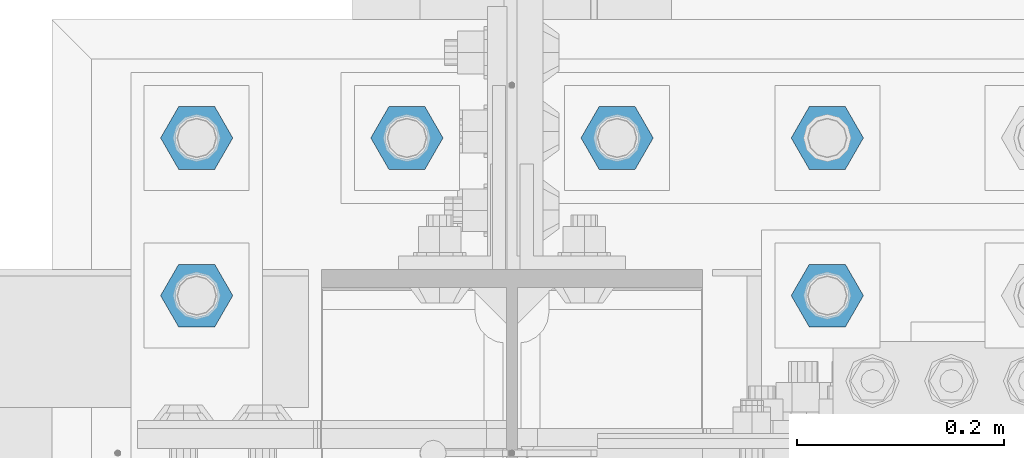
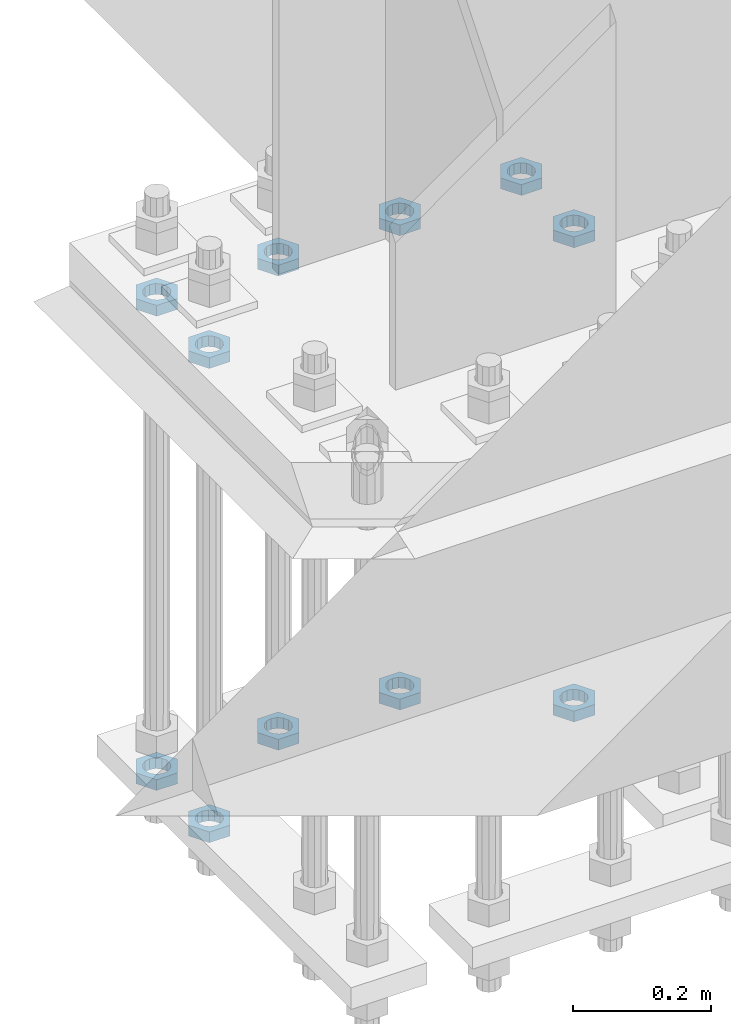
# One storey, part 2793 of 3843: 11 beams, 1 element without a shape of its own.
"""IFC2X3 building model written with IfcOpenShell, lengths in millimetres."""

from ifc_helpers import new_model, si_unit, frame, origin_with_axes, place, context, subcontext, project, spatial, faceted_brep, material, type_object, element, aggregate, save


model = new_model("IFC2X3")

# Units and contexts
model_context = context("Model", 3, precision=1e-05, world=origin_with_axes())
body_context = subcontext(model_context, "Body", "Model", "MODEL_VIEW")
ifc_project = project(units=[si_unit("LENGTHUNIT", "METRE", prefix="MILLI"), si_unit("AREAUNIT", "SQUARE_METRE"), si_unit("VOLUMEUNIT", "CUBIC_METRE"), si_unit("MASSUNIT", "GRAM", prefix="KILO"), si_unit("TIMEUNIT", "SECOND"), si_unit("PLANEANGLEUNIT", "RADIAN"), si_unit("SOLIDANGLEUNIT", "STERADIAN"), si_unit("THERMODYNAMICTEMPERATUREUNIT", "DEGREE_CELSIUS"), si_unit("LUMINOUSINTENSITYUNIT", "LUMEN")], contexts=[model_context])

# Site, building, storey
site_placement = place(None, origin_with_axes())
site = spatial("IfcSite", under=ifc_project, at=site_placement, CompositionType="ELEMENT")
building_placement = place(site_placement, origin_with_axes())
building = spatial("IfcBuilding", under=site, at=building_placement, Name="Undefined", CompositionType="ELEMENT")
storey_placement = place(building_placement, origin_with_axes())
storey = spatial("IfcBuildingStorey", under=building, at=storey_placement, Name="Undefined", CompositionType="ELEMENT", Elevation=0.0)

# Assembly, beams
assembly_placement = place(storey_placement, origin_with_axes())
assembly = element("IfcElementAssembly", 1, at=assembly_placement, inside=storey, Name="TEMPLATE", AssemblyPlace="NOTDEFINED", PredefinedType="RIGID_FRAME")
ifc_material = material(Name="STEEL/A572-50")
beam_type = type_object("IfcBeamType", Name="1-1/2_HALF_NUT", PredefinedType="NOTDEFINED")
beam_1_placement = place(assembly_placement, frame((42367.2, 25920.7, 29603.7), z_axis=(0.0, 1.0, 0.0), x_axis=(0.0, 0.0, -1.0)))
beam_1 = element("IfcBeam", 2, at=beam_1_placement, type_object=beam_type, material=ifc_material, Name="NUT", ObjectType="1-1/2_HALF_NUT", context=body_context, shape_type="Brep", body=[
    faceted_brep([(0.0, -34.9199981689453, 0.0), (0.0, -17.4599990844727, -30.25), (19.0500000000029, -17.4599990844727, -30.25), (19.0500000000029, -34.9199981689453, 0.0), (0.0, 17.4599990844727, -30.25), (19.0500000000029, 17.4599990844727, -30.25), (0.0, 34.9199981689453, 0.0), (19.0500000000029, 34.9199981689453, 0.0), (0.0, 17.4599990844727, 30.25), (19.0500000000029, 17.4599990844727, 30.25), (0.0, -17.4599990844727, 30.25), (19.0500000000029, -17.4599990844727, 30.25), (0.0, 0.0, 20.6399993896484), (0.0, 8.9553601105581, 18.5959968835959), (19.0500000000029, 8.95536011056538, 18.5959968835959), (19.0500000000029, 0.0, 20.6399993896484), (0.0, 16.1370013209525, 12.8688291298167), (19.0500000000029, 16.1370013209489, 12.8688291298167), (0.0, 20.1225115123816, 4.59283194104501), (19.0500000000029, 20.1225115123852, 4.59283194104501), (0.0, 20.1225115123816, -4.59283194104501), (19.0500000000029, 20.1225115123852, -4.59283194104501), (0.0, 16.1370013209525, -12.8688291298167), (19.0500000000029, 16.1370013209489, -12.8688291298167), (0.0, 8.9553601105581, -18.5959968835959), (19.0500000000029, 8.95536011056538, -18.5959968835959), (0.0, 0.0, -20.6399993896484), (19.0500000000029, 0.0, -20.6399993896484), (0.0, -8.9553601105581, -18.5959968835959), (19.0500000000029, -8.95536011056538, -18.5959968835959), (0.0, -16.1370013209525, -12.8688291298167), (19.0500000000029, -16.1370013209489, -12.8688291298167), (0.0, -20.1225115123816, -4.59283194104501), (19.0500000000029, -20.1225115123852, -4.59283194104501), (0.0, -20.1225115123816, 4.59283194104501), (19.0500000000029, -20.1225115123852, 4.59283194104501), (0.0, -16.1370013209525, 12.8688291298167), (19.0500000000029, -16.1370013209489, 12.8688291298167), (0.0, -8.9553601105581, 18.5959968835959), (19.0500000000029, -8.95536011056538, 18.5959968835959)], [[[0, 1, 2, 3]], [[1, 4, 5, 2]], [[4, 6, 7, 5]], [[6, 8, 9, 7]], [[8, 10, 11, 9]], [[10, 0, 3, 11]], [[12, 13, 14, 15]], [[13, 16, 17, 14]], [[16, 18, 19, 17]], [[18, 20, 21, 19]], [[20, 22, 23, 21]], [[22, 24, 25, 23]], [[24, 26, 27, 25]], [[26, 28, 29, 27]], [[28, 30, 31, 29]], [[30, 32, 33, 31]], [[32, 34, 35, 33]], [[34, 36, 37, 35]], [[36, 38, 39, 37]], [[38, 12, 15, 39]], [[5, 7, 9, 11, 3, 2], [17, 19, 21, 23, 25, 27, 29, 31, 33, 35, 37, 39, 15, 14]], [[10, 8, 6, 4, 1, 0], [38, 36, 34, 32, 30, 28, 26, 24, 22, 20, 18, 16, 13, 12]]]),
])
beam_2_placement = place(assembly_placement, frame((42367.2, 25768.3, 29603.7), z_axis=(0.0, 1.0, 0.0), x_axis=(0.0, 0.0, -1.0)))
beam_2 = element("IfcBeam", 3, at=beam_2_placement, type_object=beam_type, material=ifc_material, Name="NUT", ObjectType="1-1/2_HALF_NUT", context=body_context, shape_type="Brep", body=[
    faceted_brep([(0.0, -34.9199981689453, 0.0), (0.0, -17.4599990844727, -30.25), (19.0500000000029, -17.4599990844727, -30.25), (19.0500000000029, -34.9199981689453, 0.0), (0.0, 17.4599990844727, -30.25), (19.0500000000029, 17.4599990844727, -30.25), (0.0, 34.9199981689453, 0.0), (19.0500000000029, 34.9199981689453, 0.0), (0.0, 17.4599990844727, 30.25), (19.0500000000029, 17.4599990844727, 30.25), (0.0, -17.4599990844727, 30.25), (19.0500000000029, -17.4599990844727, 30.25), (0.0, 0.0, 20.6399993896484), (0.0, 8.9553601105581, 18.5959968835959), (19.0500000000029, 8.95536011056538, 18.5959968835959), (19.0500000000029, 0.0, 20.6399993896484), (0.0, 16.1370013209525, 12.8688291298167), (19.0500000000029, 16.1370013209489, 12.8688291298167), (0.0, 20.1225115123816, 4.59283194104501), (19.0500000000029, 20.1225115123852, 4.59283194104501), (0.0, 20.1225115123816, -4.59283194104501), (19.0500000000029, 20.1225115123852, -4.59283194104501), (0.0, 16.1370013209525, -12.8688291298167), (19.0500000000029, 16.1370013209489, -12.8688291298167), (0.0, 8.9553601105581, -18.5959968835959), (19.0500000000029, 8.95536011056538, -18.5959968835959), (0.0, 0.0, -20.6399993896484), (19.0500000000029, 0.0, -20.6399993896484), (0.0, -8.9553601105581, -18.5959968835959), (19.0500000000029, -8.95536011056538, -18.5959968835959), (0.0, -16.1370013209525, -12.8688291298167), (19.0500000000029, -16.1370013209489, -12.8688291298167), (0.0, -20.1225115123816, -4.59283194104501), (19.0500000000029, -20.1225115123852, -4.59283194104501), (0.0, -20.1225115123816, 4.59283194104501), (19.0500000000029, -20.1225115123852, 4.59283194104501), (0.0, -16.1370013209525, 12.8688291298167), (19.0500000000029, -16.1370013209489, 12.8688291298167), (0.0, -8.9553601105581, 18.5959968835959), (19.0500000000029, -8.95536011056538, 18.5959968835959)], [[[0, 1, 2, 3]], [[1, 4, 5, 2]], [[4, 6, 7, 5]], [[6, 8, 9, 7]], [[8, 10, 11, 9]], [[10, 0, 3, 11]], [[12, 13, 14, 15]], [[13, 16, 17, 14]], [[16, 18, 19, 17]], [[18, 20, 21, 19]], [[20, 22, 23, 21]], [[22, 24, 25, 23]], [[24, 26, 27, 25]], [[26, 28, 29, 27]], [[28, 30, 31, 29]], [[30, 32, 33, 31]], [[32, 34, 35, 33]], [[34, 36, 37, 35]], [[36, 38, 39, 37]], [[38, 12, 15, 39]], [[5, 7, 9, 11, 3, 2], [17, 19, 21, 23, 25, 27, 29, 31, 33, 35, 37, 39, 15, 14]], [[10, 8, 6, 4, 1, 0], [38, 36, 34, 32, 30, 28, 26, 24, 22, 20, 18, 16, 13, 12]]]),
])
beam_3_placement = place(assembly_placement, frame((42164.0, 25920.7, 29603.7), z_axis=(0.0, -1.0, 0.0), x_axis=(0.0, 0.0, -1.0)))
beam_3 = element("IfcBeam", 4, at=beam_3_placement, type_object=beam_type, material=ifc_material, Name="NUT", ObjectType="1-1/2_HALF_NUT", context=body_context, shape_type="Brep", body=[
    faceted_brep([(0.0, -34.9199981689453, 0.0), (0.0, -17.4599990844727, -30.25), (19.0500000000029, -17.4599990844727, -30.25), (19.0500000000029, -34.9199981689453, 0.0), (0.0, 17.4599990844727, -30.25), (19.0500000000029, 17.4599990844727, -30.25), (0.0, 34.9199981689453, 0.0), (19.0500000000029, 34.9199981689453, 0.0), (0.0, 17.4599990844727, 30.25), (19.0500000000029, 17.4599990844727, 30.25), (0.0, -17.4599990844727, 30.25), (19.0500000000029, -17.4599990844727, 30.25), (0.0, 0.0, 20.6399993896484), (0.0, 8.9553601105581, 18.5959968835959), (19.0500000000029, 8.95536011056538, 18.5959968835959), (19.0500000000029, 0.0, 20.6399993896484), (0.0, 16.1370013209525, 12.8688291298167), (19.0500000000029, 16.1370013209489, 12.8688291298167), (0.0, 20.1225115123816, 4.59283194104501), (19.0500000000029, 20.1225115123852, 4.59283194104501), (0.0, 20.1225115123816, -4.59283194104501), (19.0500000000029, 20.1225115123852, -4.59283194104501), (0.0, 16.1370013209525, -12.8688291298167), (19.0500000000029, 16.1370013209489, -12.8688291298167), (0.0, 8.9553601105581, -18.5959968835959), (19.0500000000029, 8.95536011056538, -18.5959968835959), (0.0, 0.0, -20.6399993896484), (19.0500000000029, 0.0, -20.6399993896484), (0.0, -8.9553601105581, -18.5959968835959), (19.0500000000029, -8.95536011056538, -18.5959968835959), (0.0, -16.1370013209525, -12.8688291298167), (19.0500000000029, -16.1370013209489, -12.8688291298167), (0.0, -20.1225115123816, -4.59283194104501), (19.0500000000029, -20.1225115123852, -4.59283194104501), (0.0, -20.1225115123816, 4.59283194104501), (19.0500000000029, -20.1225115123852, 4.59283194104501), (0.0, -16.1370013209525, 12.8688291298167), (19.0500000000029, -16.1370013209489, 12.8688291298167), (0.0, -8.9553601105581, 18.5959968835959), (19.0500000000029, -8.95536011056538, 18.5959968835959)], [[[0, 1, 2, 3]], [[1, 4, 5, 2]], [[4, 6, 7, 5]], [[6, 8, 9, 7]], [[8, 10, 11, 9]], [[10, 0, 3, 11]], [[12, 13, 14, 15]], [[13, 16, 17, 14]], [[16, 18, 19, 17]], [[18, 20, 21, 19]], [[20, 22, 23, 21]], [[22, 24, 25, 23]], [[24, 26, 27, 25]], [[26, 28, 29, 27]], [[28, 30, 31, 29]], [[30, 32, 33, 31]], [[32, 34, 35, 33]], [[34, 36, 37, 35]], [[36, 38, 39, 37]], [[38, 12, 15, 39]], [[5, 7, 9, 11, 3, 2], [17, 19, 21, 23, 25, 27, 29, 31, 33, 35, 37, 39, 15, 14]], [[10, 8, 6, 4, 1, 0], [38, 36, 34, 32, 30, 28, 26, 24, 22, 20, 18, 16, 13, 12]]]),
])
beam_4_placement = place(assembly_placement, frame((41960.8, 25920.7, 29603.7), z_axis=(0.0, -1.0, 0.0), x_axis=(0.0, 0.0, -1.0)))
beam_4 = element("IfcBeam", 5, at=beam_4_placement, type_object=beam_type, material=ifc_material, Name="NUT", ObjectType="1-1/2_HALF_NUT", context=body_context, shape_type="Brep", body=[
    faceted_brep([(0.0, -34.9199981689453, 0.0), (0.0, -17.4599990844727, -30.25), (19.0500000000029, -17.4599990844727, -30.25), (19.0500000000029, -34.9199981689453, 0.0), (0.0, 17.4599990844727, -30.25), (19.0500000000029, 17.4599990844727, -30.25), (0.0, 34.9199981689453, 0.0), (19.0500000000029, 34.9199981689453, 0.0), (0.0, 17.4599990844727, 30.25), (19.0500000000029, 17.4599990844727, 30.25), (0.0, -17.4599990844727, 30.25), (19.0500000000029, -17.4599990844727, 30.25), (0.0, 0.0, 20.6399993896484), (0.0, 8.9553601105581, 18.5959968835959), (19.0500000000029, 8.95536011056538, 18.5959968835959), (19.0500000000029, 0.0, 20.6399993896484), (0.0, 16.1370013209525, 12.8688291298167), (19.0500000000029, 16.1370013209489, 12.8688291298167), (0.0, 20.1225115123816, 4.59283194104501), (19.0500000000029, 20.1225115123852, 4.59283194104501), (0.0, 20.1225115123816, -4.59283194104501), (19.0500000000029, 20.1225115123852, -4.59283194104501), (0.0, 16.1370013209525, -12.8688291298167), (19.0500000000029, 16.1370013209489, -12.8688291298167), (0.0, 8.9553601105581, -18.5959968835959), (19.0500000000029, 8.95536011056538, -18.5959968835959), (0.0, 0.0, -20.6399993896484), (19.0500000000029, 0.0, -20.6399993896484), (0.0, -8.9553601105581, -18.5959968835959), (19.0500000000029, -8.95536011056538, -18.5959968835959), (0.0, -16.1370013209525, -12.8688291298167), (19.0500000000029, -16.1370013209489, -12.8688291298167), (0.0, -20.1225115123816, -4.59283194104501), (19.0500000000029, -20.1225115123852, -4.59283194104501), (0.0, -20.1225115123816, 4.59283194104501), (19.0500000000029, -20.1225115123852, 4.59283194104501), (0.0, -16.1370013209525, 12.8688291298167), (19.0500000000029, -16.1370013209489, 12.8688291298167), (0.0, -8.9553601105581, 18.5959968835959), (19.0500000000029, -8.95536011056538, 18.5959968835959)], [[[0, 1, 2, 3]], [[1, 4, 5, 2]], [[4, 6, 7, 5]], [[6, 8, 9, 7]], [[8, 10, 11, 9]], [[10, 0, 3, 11]], [[12, 13, 14, 15]], [[13, 16, 17, 14]], [[16, 18, 19, 17]], [[18, 20, 21, 19]], [[20, 22, 23, 21]], [[22, 24, 25, 23]], [[24, 26, 27, 25]], [[26, 28, 29, 27]], [[28, 30, 31, 29]], [[30, 32, 33, 31]], [[32, 34, 35, 33]], [[34, 36, 37, 35]], [[36, 38, 39, 37]], [[38, 12, 15, 39]], [[5, 7, 9, 11, 3, 2], [17, 19, 21, 23, 25, 27, 29, 31, 33, 35, 37, 39, 15, 14]], [[10, 8, 6, 4, 1, 0], [38, 36, 34, 32, 30, 28, 26, 24, 22, 20, 18, 16, 13, 12]]]),
])
beam_5_placement = place(assembly_placement, frame((41757.6, 25920.7, 29603.7), z_axis=(0.0, -1.0, 0.0), x_axis=(0.0, 0.0, -1.0)))
beam_5 = element("IfcBeam", 6, at=beam_5_placement, type_object=beam_type, material=ifc_material, Name="NUT", ObjectType="1-1/2_HALF_NUT", context=body_context, shape_type="Brep", body=[
    faceted_brep([(0.0, -34.9199981689453, 0.0), (0.0, -17.4599990844727, -30.25), (19.0500000000029, -17.4599990844727, -30.25), (19.0500000000029, -34.9199981689453, 0.0), (0.0, 17.4599990844727, -30.25), (19.0500000000029, 17.4599990844727, -30.25), (0.0, 34.9199981689453, 0.0), (19.0500000000029, 34.9199981689453, 0.0), (0.0, 17.4599990844727, 30.25), (19.0500000000029, 17.4599990844727, 30.25), (0.0, -17.4599990844727, 30.25), (19.0500000000029, -17.4599990844727, 30.25), (0.0, 0.0, 20.6399993896484), (0.0, 8.9553601105581, 18.5959968835959), (19.0500000000029, 8.95536011056538, 18.5959968835959), (19.0500000000029, 0.0, 20.6399993896484), (0.0, 16.1370013209525, 12.8688291298167), (19.0500000000029, 16.1370013209489, 12.8688291298167), (0.0, 20.1225115123816, 4.59283194104501), (19.0500000000029, 20.1225115123852, 4.59283194104501), (0.0, 20.1225115123816, -4.59283194104501), (19.0500000000029, 20.1225115123852, -4.59283194104501), (0.0, 16.1370013209525, -12.8688291298167), (19.0500000000029, 16.1370013209489, -12.8688291298167), (0.0, 8.9553601105581, -18.5959968835959), (19.0500000000029, 8.95536011056538, -18.5959968835959), (0.0, 0.0, -20.6399993896484), (19.0500000000029, 0.0, -20.6399993896484), (0.0, -8.9553601105581, -18.5959968835959), (19.0500000000029, -8.95536011056538, -18.5959968835959), (0.0, -16.1370013209525, -12.8688291298167), (19.0500000000029, -16.1370013209489, -12.8688291298167), (0.0, -20.1225115123816, -4.59283194104501), (19.0500000000029, -20.1225115123852, -4.59283194104501), (0.0, -20.1225115123816, 4.59283194104501), (19.0500000000029, -20.1225115123852, 4.59283194104501), (0.0, -16.1370013209525, 12.8688291298167), (19.0500000000029, -16.1370013209489, 12.8688291298167), (0.0, -8.9553601105581, 18.5959968835959), (19.0500000000029, -8.95536011056538, 18.5959968835959)], [[[0, 1, 2, 3]], [[1, 4, 5, 2]], [[4, 6, 7, 5]], [[6, 8, 9, 7]], [[8, 10, 11, 9]], [[10, 0, 3, 11]], [[12, 13, 14, 15]], [[13, 16, 17, 14]], [[16, 18, 19, 17]], [[18, 20, 21, 19]], [[20, 22, 23, 21]], [[22, 24, 25, 23]], [[24, 26, 27, 25]], [[26, 28, 29, 27]], [[28, 30, 31, 29]], [[30, 32, 33, 31]], [[32, 34, 35, 33]], [[34, 36, 37, 35]], [[36, 38, 39, 37]], [[38, 12, 15, 39]], [[5, 7, 9, 11, 3, 2], [17, 19, 21, 23, 25, 27, 29, 31, 33, 35, 37, 39, 15, 14]], [[10, 8, 6, 4, 1, 0], [38, 36, 34, 32, 30, 28, 26, 24, 22, 20, 18, 16, 13, 12]]]),
])
beam_6_placement = place(assembly_placement, frame((41757.6, 25768.3, 29603.7), z_axis=(0.0, -1.0, 0.0), x_axis=(0.0, 0.0, -1.0)))
beam_6 = element("IfcBeam", 7, at=beam_6_placement, type_object=beam_type, material=ifc_material, Name="NUT", ObjectType="1-1/2_HALF_NUT", context=body_context, shape_type="Brep", body=[
    faceted_brep([(0.0, -34.9199981689453, 0.0), (0.0, -17.4599990844727, -30.25), (19.0500000000029, -17.4599990844727, -30.25), (19.0500000000029, -34.9199981689453, 0.0), (0.0, 17.4599990844727, -30.25), (19.0500000000029, 17.4599990844727, -30.25), (0.0, 34.9199981689453, 0.0), (19.0500000000029, 34.9199981689453, 0.0), (0.0, 17.4599990844727, 30.25), (19.0500000000029, 17.4599990844727, 30.25), (0.0, -17.4599990844727, 30.25), (19.0500000000029, -17.4599990844727, 30.25), (0.0, 0.0, 20.6399993896484), (0.0, 8.9553601105581, 18.5959968835959), (19.0500000000029, 8.95536011056538, 18.5959968835959), (19.0500000000029, 0.0, 20.6399993896484), (0.0, 16.1370013209525, 12.8688291298167), (19.0500000000029, 16.1370013209489, 12.8688291298167), (0.0, 20.1225115123816, 4.59283194104501), (19.0500000000029, 20.1225115123852, 4.59283194104501), (0.0, 20.1225115123816, -4.59283194104501), (19.0500000000029, 20.1225115123852, -4.59283194104501), (0.0, 16.1370013209525, -12.8688291298167), (19.0500000000029, 16.1370013209489, -12.8688291298167), (0.0, 8.9553601105581, -18.5959968835959), (19.0500000000029, 8.95536011056538, -18.5959968835959), (0.0, 0.0, -20.6399993896484), (19.0500000000029, 0.0, -20.6399993896484), (0.0, -8.9553601105581, -18.5959968835959), (19.0500000000029, -8.95536011056538, -18.5959968835959), (0.0, -16.1370013209525, -12.8688291298167), (19.0500000000029, -16.1370013209489, -12.8688291298167), (0.0, -20.1225115123816, -4.59283194104501), (19.0500000000029, -20.1225115123852, -4.59283194104501), (0.0, -20.1225115123816, 4.59283194104501), (19.0500000000029, -20.1225115123852, 4.59283194104501), (0.0, -16.1370013209525, 12.8688291298167), (19.0500000000029, -16.1370013209489, 12.8688291298167), (0.0, -8.9553601105581, 18.5959968835959), (19.0500000000029, -8.95536011056538, 18.5959968835959)], [[[0, 1, 2, 3]], [[1, 4, 5, 2]], [[4, 6, 7, 5]], [[6, 8, 9, 7]], [[8, 10, 11, 9]], [[10, 0, 3, 11]], [[12, 13, 14, 15]], [[13, 16, 17, 14]], [[16, 18, 19, 17]], [[18, 20, 21, 19]], [[20, 22, 23, 21]], [[22, 24, 25, 23]], [[24, 26, 27, 25]], [[26, 28, 29, 27]], [[28, 30, 31, 29]], [[30, 32, 33, 31]], [[32, 34, 35, 33]], [[34, 36, 37, 35]], [[36, 38, 39, 37]], [[38, 12, 15, 39]], [[5, 7, 9, 11, 3, 2], [17, 19, 21, 23, 25, 27, 29, 31, 33, 35, 37, 39, 15, 14]], [[10, 8, 6, 4, 1, 0], [38, 36, 34, 32, 30, 28, 26, 24, 22, 20, 18, 16, 13, 12]]]),
])
beam_7_placement = place(assembly_placement, frame((41757.6, 25768.3, 28765.5000015259), z_axis=(0.0, -1.0, 0.0), x_axis=(0.0, 0.0, -1.0)))
beam_7 = element("IfcBeam", 8, at=beam_7_placement, type_object=beam_type, material=ifc_material, Name="NUT", ObjectType="1-1/2_HALF_NUT", context=body_context, shape_type="Brep", body=[
    faceted_brep([(0.0, -34.9199981689453, 0.0), (0.0, -17.4599990844727, -30.25), (19.0500000000029, -17.4599990844727, -30.25), (19.0500000000029, -34.9199981689453, 0.0), (0.0, 17.4599990844727, -30.25), (19.0500000000029, 17.4599990844727, -30.25), (0.0, 34.9199981689453, 0.0), (19.0500000000029, 34.9199981689453, 0.0), (0.0, 17.4599990844727, 30.25), (19.0500000000029, 17.4599990844727, 30.25), (0.0, -17.4599990844727, 30.25), (19.0500000000029, -17.4599990844727, 30.25), (0.0, 0.0, 20.6399993896484), (0.0, 8.9553601105581, 18.5959968835959), (19.0500000000029, 8.95536011056538, 18.5959968835959), (19.0500000000029, 0.0, 20.6399993896484), (0.0, 16.1370013209525, 12.8688291298167), (19.0500000000029, 16.1370013209489, 12.8688291298167), (0.0, 20.1225115123816, 4.59283194104501), (19.0500000000029, 20.1225115123852, 4.59283194104501), (0.0, 20.1225115123816, -4.59283194104501), (19.0500000000029, 20.1225115123852, -4.59283194104501), (0.0, 16.1370013209525, -12.8688291298167), (19.0500000000029, 16.1370013209489, -12.8688291298167), (0.0, 8.9553601105581, -18.5959968835959), (19.0500000000029, 8.95536011056538, -18.5959968835959), (0.0, 0.0, -20.6399993896484), (19.0500000000029, 0.0, -20.6399993896484), (0.0, -8.9553601105581, -18.5959968835959), (19.0500000000029, -8.95536011056538, -18.5959968835959), (0.0, -16.1370013209525, -12.8688291298167), (19.0500000000029, -16.1370013209489, -12.8688291298167), (0.0, -20.1225115123816, -4.59283194104501), (19.0500000000029, -20.1225115123852, -4.59283194104501), (0.0, -20.1225115123816, 4.59283194104501), (19.0500000000029, -20.1225115123852, 4.59283194104501), (0.0, -16.1370013209525, 12.8688291298167), (19.0500000000029, -16.1370013209489, 12.8688291298167), (0.0, -8.9553601105581, 18.5959968835959), (19.0500000000029, -8.95536011056538, 18.5959968835959)], [[[0, 1, 2, 3]], [[1, 4, 5, 2]], [[4, 6, 7, 5]], [[6, 8, 9, 7]], [[8, 10, 11, 9]], [[10, 0, 3, 11]], [[12, 13, 14, 15]], [[13, 16, 17, 14]], [[16, 18, 19, 17]], [[18, 20, 21, 19]], [[20, 22, 23, 21]], [[22, 24, 25, 23]], [[24, 26, 27, 25]], [[26, 28, 29, 27]], [[28, 30, 31, 29]], [[30, 32, 33, 31]], [[32, 34, 35, 33]], [[34, 36, 37, 35]], [[36, 38, 39, 37]], [[38, 12, 15, 39]], [[5, 7, 9, 11, 3, 2], [17, 19, 21, 23, 25, 27, 29, 31, 33, 35, 37, 39, 15, 14]], [[10, 8, 6, 4, 1, 0], [38, 36, 34, 32, 30, 28, 26, 24, 22, 20, 18, 16, 13, 12]]]),
])
beam_8_placement = place(assembly_placement, frame((42367.2, 25768.3, 28765.5000015259), z_axis=(0.0, 1.0, 0.0), x_axis=(0.0, 0.0, -1.0)))
beam_8 = element("IfcBeam", 9, at=beam_8_placement, type_object=beam_type, material=ifc_material, Name="NUT", ObjectType="1-1/2_HALF_NUT", context=body_context, shape_type="Brep", body=[
    faceted_brep([(0.0, -34.9199981689453, 0.0), (0.0, -17.4599990844727, -30.25), (19.0500000000029, -17.4599990844727, -30.25), (19.0500000000029, -34.9199981689453, 0.0), (0.0, 17.4599990844727, -30.25), (19.0500000000029, 17.4599990844727, -30.25), (0.0, 34.9199981689453, 0.0), (19.0500000000029, 34.9199981689453, 0.0), (0.0, 17.4599990844727, 30.25), (19.0500000000029, 17.4599990844727, 30.25), (0.0, -17.4599990844727, 30.25), (19.0500000000029, -17.4599990844727, 30.25), (0.0, 0.0, 20.6399993896484), (0.0, 8.9553601105581, 18.5959968835959), (19.0500000000029, 8.95536011056538, 18.5959968835959), (19.0500000000029, 0.0, 20.6399993896484), (0.0, 16.1370013209525, 12.8688291298167), (19.0500000000029, 16.1370013209489, 12.8688291298167), (0.0, 20.1225115123816, 4.59283194104501), (19.0500000000029, 20.1225115123852, 4.59283194104501), (0.0, 20.1225115123816, -4.59283194104501), (19.0500000000029, 20.1225115123852, -4.59283194104501), (0.0, 16.1370013209525, -12.8688291298167), (19.0500000000029, 16.1370013209489, -12.8688291298167), (0.0, 8.9553601105581, -18.5959968835959), (19.0500000000029, 8.95536011056538, -18.5959968835959), (0.0, 0.0, -20.6399993896484), (19.0500000000029, 0.0, -20.6399993896484), (0.0, -8.9553601105581, -18.5959968835959), (19.0500000000029, -8.95536011056538, -18.5959968835959), (0.0, -16.1370013209525, -12.8688291298167), (19.0500000000029, -16.1370013209489, -12.8688291298167), (0.0, -20.1225115123816, -4.59283194104501), (19.0500000000029, -20.1225115123852, -4.59283194104501), (0.0, -20.1225115123816, 4.59283194104501), (19.0500000000029, -20.1225115123852, 4.59283194104501), (0.0, -16.1370013209525, 12.8688291298167), (19.0500000000029, -16.1370013209489, 12.8688291298167), (0.0, -8.9553601105581, 18.5959968835959), (19.0500000000029, -8.95536011056538, 18.5959968835959)], [[[0, 1, 2, 3]], [[1, 4, 5, 2]], [[4, 6, 7, 5]], [[6, 8, 9, 7]], [[8, 10, 11, 9]], [[10, 0, 3, 11]], [[12, 13, 14, 15]], [[13, 16, 17, 14]], [[16, 18, 19, 17]], [[18, 20, 21, 19]], [[20, 22, 23, 21]], [[22, 24, 25, 23]], [[24, 26, 27, 25]], [[26, 28, 29, 27]], [[28, 30, 31, 29]], [[30, 32, 33, 31]], [[32, 34, 35, 33]], [[34, 36, 37, 35]], [[36, 38, 39, 37]], [[38, 12, 15, 39]], [[5, 7, 9, 11, 3, 2], [17, 19, 21, 23, 25, 27, 29, 31, 33, 35, 37, 39, 15, 14]], [[10, 8, 6, 4, 1, 0], [38, 36, 34, 32, 30, 28, 26, 24, 22, 20, 18, 16, 13, 12]]]),
])
beam_9_placement = place(assembly_placement, frame((41757.6, 25920.7, 28765.5000015259), z_axis=(0.0, -1.0, 0.0), x_axis=(0.0, 0.0, -1.0)))
beam_9 = element("IfcBeam", 10, at=beam_9_placement, type_object=beam_type, material=ifc_material, Name="NUT", ObjectType="1-1/2_HALF_NUT", context=body_context, shape_type="Brep", body=[
    faceted_brep([(0.0, -34.9199981689453, 0.0), (0.0, -17.4599990844727, -30.25), (19.0500000000029, -17.4599990844727, -30.25), (19.0500000000029, -34.9199981689453, 0.0), (0.0, 17.4599990844727, -30.25), (19.0500000000029, 17.4599990844727, -30.25), (0.0, 34.9199981689453, 0.0), (19.0500000000029, 34.9199981689453, 0.0), (0.0, 17.4599990844727, 30.25), (19.0500000000029, 17.4599990844727, 30.25), (0.0, -17.4599990844727, 30.25), (19.0500000000029, -17.4599990844727, 30.25), (0.0, 0.0, 20.6399993896484), (0.0, 8.9553601105581, 18.5959968835959), (19.0500000000029, 8.95536011056538, 18.5959968835959), (19.0500000000029, 0.0, 20.6399993896484), (0.0, 16.1370013209525, 12.8688291298167), (19.0500000000029, 16.1370013209489, 12.8688291298167), (0.0, 20.1225115123816, 4.59283194104501), (19.0500000000029, 20.1225115123852, 4.59283194104501), (0.0, 20.1225115123816, -4.59283194104501), (19.0500000000029, 20.1225115123852, -4.59283194104501), (0.0, 16.1370013209525, -12.8688291298167), (19.0500000000029, 16.1370013209489, -12.8688291298167), (0.0, 8.9553601105581, -18.5959968835959), (19.0500000000029, 8.95536011056538, -18.5959968835959), (0.0, 0.0, -20.6399993896484), (19.0500000000029, 0.0, -20.6399993896484), (0.0, -8.9553601105581, -18.5959968835959), (19.0500000000029, -8.95536011056538, -18.5959968835959), (0.0, -16.1370013209525, -12.8688291298167), (19.0500000000029, -16.1370013209489, -12.8688291298167), (0.0, -20.1225115123816, -4.59283194104501), (19.0500000000029, -20.1225115123852, -4.59283194104501), (0.0, -20.1225115123816, 4.59283194104501), (19.0500000000029, -20.1225115123852, 4.59283194104501), (0.0, -16.1370013209525, 12.8688291298167), (19.0500000000029, -16.1370013209489, 12.8688291298167), (0.0, -8.9553601105581, 18.5959968835959), (19.0500000000029, -8.95536011056538, 18.5959968835959)], [[[0, 1, 2, 3]], [[1, 4, 5, 2]], [[4, 6, 7, 5]], [[6, 8, 9, 7]], [[8, 10, 11, 9]], [[10, 0, 3, 11]], [[12, 13, 14, 15]], [[13, 16, 17, 14]], [[16, 18, 19, 17]], [[18, 20, 21, 19]], [[20, 22, 23, 21]], [[22, 24, 25, 23]], [[24, 26, 27, 25]], [[26, 28, 29, 27]], [[28, 30, 31, 29]], [[30, 32, 33, 31]], [[32, 34, 35, 33]], [[34, 36, 37, 35]], [[36, 38, 39, 37]], [[38, 12, 15, 39]], [[5, 7, 9, 11, 3, 2], [17, 19, 21, 23, 25, 27, 29, 31, 33, 35, 37, 39, 15, 14]], [[10, 8, 6, 4, 1, 0], [38, 36, 34, 32, 30, 28, 26, 24, 22, 20, 18, 16, 13, 12]]]),
])
beam_10_placement = place(assembly_placement, frame((41960.8, 25920.7, 28765.5000015259), z_axis=(0.0, -1.0, 0.0), x_axis=(0.0, 0.0, -1.0)))
beam_10 = element("IfcBeam", 11, at=beam_10_placement, type_object=beam_type, material=ifc_material, Name="NUT", ObjectType="1-1/2_HALF_NUT", context=body_context, shape_type="Brep", body=[
    faceted_brep([(0.0, -34.9199981689453, 0.0), (0.0, -17.4599990844727, -30.25), (19.0500000000029, -17.4599990844727, -30.25), (19.0500000000029, -34.9199981689453, 0.0), (0.0, 17.4599990844727, -30.25), (19.0500000000029, 17.4599990844727, -30.25), (0.0, 34.9199981689453, 0.0), (19.0500000000029, 34.9199981689453, 0.0), (0.0, 17.4599990844727, 30.25), (19.0500000000029, 17.4599990844727, 30.25), (0.0, -17.4599990844727, 30.25), (19.0500000000029, -17.4599990844727, 30.25), (0.0, 0.0, 20.6399993896484), (0.0, 8.9553601105581, 18.5959968835959), (19.0500000000029, 8.95536011056538, 18.5959968835959), (19.0500000000029, 0.0, 20.6399993896484), (0.0, 16.1370013209525, 12.8688291298167), (19.0500000000029, 16.1370013209489, 12.8688291298167), (0.0, 20.1225115123816, 4.59283194104501), (19.0500000000029, 20.1225115123852, 4.59283194104501), (0.0, 20.1225115123816, -4.59283194104501), (19.0500000000029, 20.1225115123852, -4.59283194104501), (0.0, 16.1370013209525, -12.8688291298167), (19.0500000000029, 16.1370013209489, -12.8688291298167), (0.0, 8.9553601105581, -18.5959968835959), (19.0500000000029, 8.95536011056538, -18.5959968835959), (0.0, 0.0, -20.6399993896484), (19.0500000000029, 0.0, -20.6399993896484), (0.0, -8.9553601105581, -18.5959968835959), (19.0500000000029, -8.95536011056538, -18.5959968835959), (0.0, -16.1370013209525, -12.8688291298167), (19.0500000000029, -16.1370013209489, -12.8688291298167), (0.0, -20.1225115123816, -4.59283194104501), (19.0500000000029, -20.1225115123852, -4.59283194104501), (0.0, -20.1225115123816, 4.59283194104501), (19.0500000000029, -20.1225115123852, 4.59283194104501), (0.0, -16.1370013209525, 12.8688291298167), (19.0500000000029, -16.1370013209489, 12.8688291298167), (0.0, -8.9553601105581, 18.5959968835959), (19.0500000000029, -8.95536011056538, 18.5959968835959)], [[[0, 1, 2, 3]], [[1, 4, 5, 2]], [[4, 6, 7, 5]], [[6, 8, 9, 7]], [[8, 10, 11, 9]], [[10, 0, 3, 11]], [[12, 13, 14, 15]], [[13, 16, 17, 14]], [[16, 18, 19, 17]], [[18, 20, 21, 19]], [[20, 22, 23, 21]], [[22, 24, 25, 23]], [[24, 26, 27, 25]], [[26, 28, 29, 27]], [[28, 30, 31, 29]], [[30, 32, 33, 31]], [[32, 34, 35, 33]], [[34, 36, 37, 35]], [[36, 38, 39, 37]], [[38, 12, 15, 39]], [[5, 7, 9, 11, 3, 2], [17, 19, 21, 23, 25, 27, 29, 31, 33, 35, 37, 39, 15, 14]], [[10, 8, 6, 4, 1, 0], [38, 36, 34, 32, 30, 28, 26, 24, 22, 20, 18, 16, 13, 12]]]),
])
beam_11_placement = place(assembly_placement, frame((42164.0, 25920.7, 28765.5000015259), z_axis=(0.0, -1.0, 0.0), x_axis=(0.0, 0.0, -1.0)))
beam_11 = element("IfcBeam", 12, at=beam_11_placement, type_object=beam_type, material=ifc_material, Name="NUT", ObjectType="1-1/2_HALF_NUT", context=body_context, shape_type="Brep", body=[
    faceted_brep([(0.0, -34.9199981689453, 0.0), (0.0, -17.4599990844727, -30.25), (19.0500000000029, -17.4599990844727, -30.25), (19.0500000000029, -34.9199981689453, 0.0), (0.0, 17.4599990844727, -30.25), (19.0500000000029, 17.4599990844727, -30.25), (0.0, 34.9199981689453, 0.0), (19.0500000000029, 34.9199981689453, 0.0), (0.0, 17.4599990844727, 30.25), (19.0500000000029, 17.4599990844727, 30.25), (0.0, -17.4599990844727, 30.25), (19.0500000000029, -17.4599990844727, 30.25), (0.0, 0.0, 20.6399993896484), (0.0, 8.9553601105581, 18.5959968835959), (19.0500000000029, 8.95536011056538, 18.5959968835959), (19.0500000000029, 0.0, 20.6399993896484), (0.0, 16.1370013209525, 12.8688291298167), (19.0500000000029, 16.1370013209489, 12.8688291298167), (0.0, 20.1225115123816, 4.59283194104501), (19.0500000000029, 20.1225115123852, 4.59283194104501), (0.0, 20.1225115123816, -4.59283194104501), (19.0500000000029, 20.1225115123852, -4.59283194104501), (0.0, 16.1370013209525, -12.8688291298167), (19.0500000000029, 16.1370013209489, -12.8688291298167), (0.0, 8.9553601105581, -18.5959968835959), (19.0500000000029, 8.95536011056538, -18.5959968835959), (0.0, 0.0, -20.6399993896484), (19.0500000000029, 0.0, -20.6399993896484), (0.0, -8.9553601105581, -18.5959968835959), (19.0500000000029, -8.95536011056538, -18.5959968835959), (0.0, -16.1370013209525, -12.8688291298167), (19.0500000000029, -16.1370013209489, -12.8688291298167), (0.0, -20.1225115123816, -4.59283194104501), (19.0500000000029, -20.1225115123852, -4.59283194104501), (0.0, -20.1225115123816, 4.59283194104501), (19.0500000000029, -20.1225115123852, 4.59283194104501), (0.0, -16.1370013209525, 12.8688291298167), (19.0500000000029, -16.1370013209489, 12.8688291298167), (0.0, -8.9553601105581, 18.5959968835959), (19.0500000000029, -8.95536011056538, 18.5959968835959)], [[[0, 1, 2, 3]], [[1, 4, 5, 2]], [[4, 6, 7, 5]], [[6, 8, 9, 7]], [[8, 10, 11, 9]], [[10, 0, 3, 11]], [[12, 13, 14, 15]], [[13, 16, 17, 14]], [[16, 18, 19, 17]], [[18, 20, 21, 19]], [[20, 22, 23, 21]], [[22, 24, 25, 23]], [[24, 26, 27, 25]], [[26, 28, 29, 27]], [[28, 30, 31, 29]], [[30, 32, 33, 31]], [[32, 34, 35, 33]], [[34, 36, 37, 35]], [[36, 38, 39, 37]], [[38, 12, 15, 39]], [[5, 7, 9, 11, 3, 2], [17, 19, 21, 23, 25, 27, 29, 31, 33, 35, 37, 39, 15, 14]], [[10, 8, 6, 4, 1, 0], [38, 36, 34, 32, 30, 28, 26, 24, 22, 20, 18, 16, 13, 12]]]),
])
aggregate(assembly, [beam_1, beam_2, beam_3, beam_4, beam_5, beam_6, beam_7, beam_8, beam_9, beam_10, beam_11])

save(model, "model.ifc")
